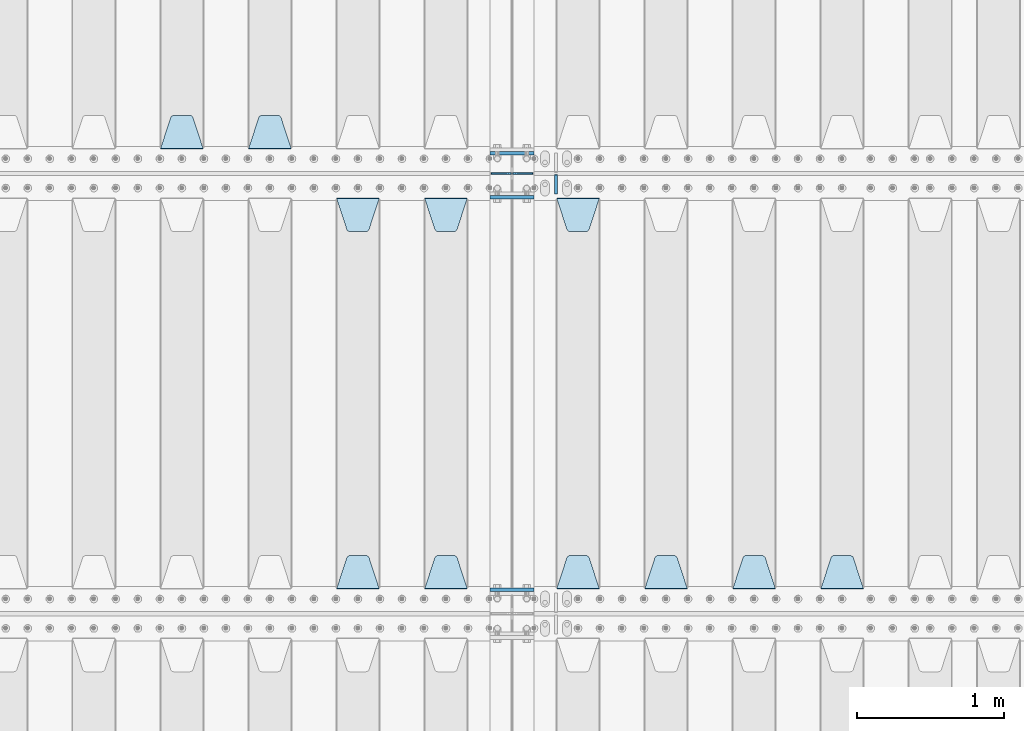
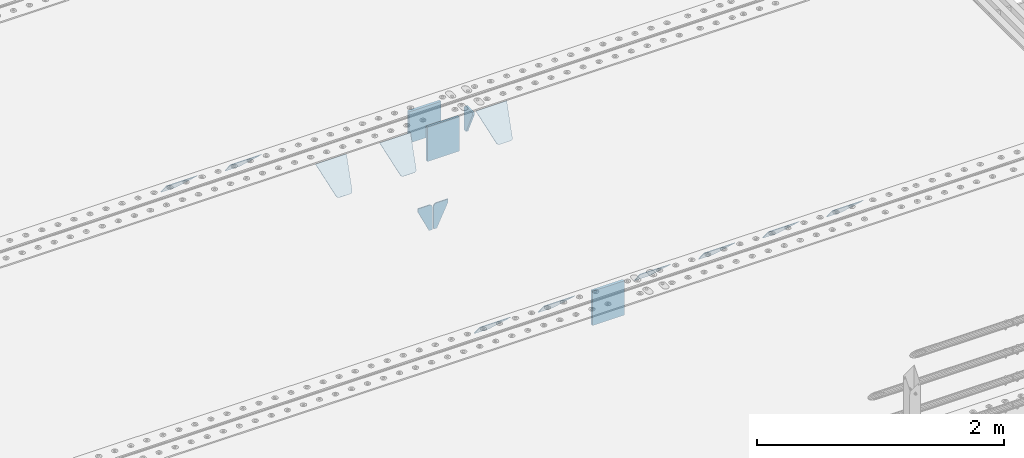
# One storey, part 215 of 257: 17 plates.
"""IFC2X3 building model written with IfcOpenShell, lengths in millimetres."""

from ifc_helpers import new_model, si_unit, frame, origin_with_axes, place, context, subcontext, project, spatial, faceted_brep, material, type_object, element, save


model = new_model("IFC2X3")

# Units and contexts
model_context = context("Model", 3, precision=1e-05, world=origin_with_axes())
body_context = subcontext(model_context, "Body", "Model", "MODEL_VIEW")
ifc_project = project(units=[si_unit("LENGTHUNIT", "METRE", prefix="MILLI"), si_unit("AREAUNIT", "SQUARE_METRE"), si_unit("VOLUMEUNIT", "CUBIC_METRE"), si_unit("MASSUNIT", "GRAM", prefix="KILO"), si_unit("TIMEUNIT", "SECOND"), si_unit("PLANEANGLEUNIT", "RADIAN"), si_unit("SOLIDANGLEUNIT", "STERADIAN"), si_unit("THERMODYNAMICTEMPERATUREUNIT", "DEGREE_CELSIUS"), si_unit("LUMINOUSINTENSITYUNIT", "LUMEN")], contexts=[model_context])

# Site, building, storey
site_placement = place(None, origin_with_axes())
site = spatial("IfcSite", under=ifc_project, at=site_placement, CompositionType="ELEMENT")
building_placement = place(site_placement, origin_with_axes())
building = spatial("IfcBuilding", under=site, at=building_placement, Name="Standard", CompositionType="ELEMENT")
storey_placement = place(building_placement, origin_with_axes())
storey = spatial("IfcBuildingStorey", under=building, at=storey_placement, Name="Undefined", CompositionType="ELEMENT", Elevation=0.0)

# Plates
ifc_material = material(Name="STEEL/S355N")
plate_type_1 = type_object("IfcPlateType", PredefinedType="NOTDEFINED")
for number, where, z_axis, x_axis in (
    (1, (54550.0, 5837.5, -340.000000000044), (0.0, 0.0, 1.0), (1.0, 0.0, 0.0)),
    (2, (54550.0, 3162.5, -340.000000000044), (0.0, 0.0, 1.0), (1.0, 0.0, 0.0)),
):
    element("IfcPlate", number, at=place(storey_placement, frame(where, z_axis=z_axis, x_axis=x_axis)), inside=storey, type_object=plate_type_1, material=ifc_material, context=body_context, shape_type="Brep", body=[
        faceted_brep([(0.0, -12.5, 0.0), (0.0, -12.5, 340.0), (0.0, 12.5, 340.0), (0.0, 12.5, 0.0), (300.0, -12.5, 340.0), (300.0, 12.5, 340.0), (300.0, -12.5, 0.0), (300.0, 12.5, 0.0)], [[[0, 1, 2, 3]], [[1, 4, 5, 2]], [[4, 6, 7, 5]], [[6, 0, 3, 7]], [[5, 7, 3, 2]], [[6, 4, 1, 0]]]),
    ])
plate_1_placement = place(storey_placement, frame((54550.0, 6137.5, -340.0), z_axis=(0.0, 0.0, 1.0), x_axis=(1.0, 0.0, 0.0)))
element("IfcPlate", 3, at=plate_1_placement, inside=storey, type_object=plate_type_1, material=ifc_material, context=body_context, shape_type="Brep", body=[
    faceted_brep([(0.0, -12.5, 0.0), (0.0, -12.5, 310.0), (0.0, 12.5, 310.0), (0.0, 12.5, 0.0), (300.0, -12.5, 310.0), (300.0, 12.5, 310.0), (300.0, -12.5, 0.0), (300.0, 12.5, 0.0)], [[[0, 1, 2, 3]], [[1, 4, 5, 2]], [[4, 6, 7, 5]], [[6, 0, 3, 7]], [[5, 7, 3, 2]], [[6, 4, 1, 0]]]),
])
plate_type_2 = type_object("IfcPlateType", PredefinedType="NOTDEFINED")
for number, where, z_axis, x_axis in (
    (4, (54693.4999999979, 6000.00000000422, -915.000019536854), (0.0, 0.0, -1.0), (-1.0, 0.0, 0.0)),
    (5, (54706.4999999981, 6000.0000000042, -915.000019536856), (0.0, 0.0, -1.0), (1.0, 0.0, 0.0)),
):
    element("IfcPlate", number, at=place(storey_placement, frame(where, z_axis=z_axis, x_axis=x_axis)), inside=storey, type_object=plate_type_2, material=ifc_material, context=body_context, shape_type="Brep", body=[
        faceted_brep([(0.0, -5.0, 27.0), (0.0, -5.0, 250.0), (0.0, 5.0, 250.0), (0.0, 5.0, 27.0), (30.0, -5.0, 250.0), (30.0, 5.0, 250.0), (135.0, -5.0, 30.0), (135.0, 5.0, 30.0), (135.0, -5.0, 0.0), (135.0, 5.0, 0.0), (27.0, -5.0, 0.0), (27.0, 5.0, 0.0), (22.311499202995, -5.0, 0.410190668670339), (22.311499202995, 5.0, 0.410190668670339), (17.7654561302043, -5.0, 1.62829923878053), (17.7654561302043, 5.0, 1.62829923878053), (13.5, -5.0, 3.6173140978201), (13.5, 5.0, 3.6173140978201), (9.64473453846585, -5.0, 6.31680003578754), (9.64473453846585, 5.0, 6.31680003578754), (6.31680003579095, -5.0, 9.64473453846347), (6.31680003579095, 5.0, 9.64473453846347), (3.61731409782078, -5.0, 13.5), (3.61731409782078, 5.0, 13.5), (1.62829923877871, -5.0, 17.765456130207), (1.62829923877871, 5.0, 17.765456130207), (0.410190668670111, -5.0, 22.3114992029929), (0.410190668670111, 5.0, 22.3114992029929)], [[[0, 1, 2, 3]], [[1, 4, 5, 2]], [[4, 6, 7, 5]], [[6, 8, 9, 7]], [[8, 10, 11, 9]], [[10, 12, 13, 11]], [[12, 14, 15, 13]], [[14, 16, 17, 15]], [[16, 18, 19, 17]], [[18, 20, 21, 19]], [[20, 22, 23, 21]], [[22, 24, 25, 23]], [[24, 26, 27, 25]], [[26, 0, 3, 27]], [[5, 7, 9, 11, 13, 15, 17, 19, 21, 23, 25, 27, 3, 2]], [[26, 24, 22, 20, 18, 16, 14, 12, 10, 8, 6, 4, 1, 0]]]),
    ])
plate_type_3 = type_object("IfcPlateType", PredefinedType="NOTDEFINED")
plate_2_placement = place(storey_placement, frame((57095.0, 3168.23223304703, -1.76776695296758), z_axis=(0.0, 0.707106781186547, -0.707106781186548), x_axis=(-1.0, 0.0, 0.0)))
element("IfcPlate", 6, at=plate_2_placement, inside=storey, type_object=plate_type_3, material=ifc_material, context=body_context, shape_type="Brep", body=[
    faceted_brep([(0.0, -2.5, 0.0), (69.345504679477, -2.50000000000091, 300.17173142483), (69.345504679477, 2.5, 300.171731424831), (0.0, 2.5, 0.0), (70.927406119954, -2.50000000000091, 304.8974424154), (70.927406119954, 2.5, 304.8974424154), (73.3818627772271, -2.50000000000091, 309.234538108527), (73.3818627772271, 2.49999999999909, 309.234538108527), (76.6187032999587, -2.5, 313.023683126103), (76.6187032999587, 2.5, 313.023683126103), (80.5190132705029, -2.5, 316.125672595372), (80.5190132705029, 2.5, 316.125672595371), (84.9395038596849, -2.5, 318.426546230476), (84.9395038596849, 2.5, 318.426546230477), (89.7177759439219, -2.5, 319.841774983275), (89.7177759439219, 2.5, 319.841774983275), (94.6782862926484, -2.5, 320.319366455079), (94.6782862926484, 2.5, 320.319366455079), (195.321713707352, -2.5, 320.319366455079), (195.321713707352, 2.5, 320.319366455079), (200.282224056078, -2.5, 319.841774983275), (200.282224056078, 2.49999999999909, 319.841774983275), (205.060496140315, -2.5, 318.426546230476), (205.060496140315, 2.49999999999909, 318.426546230475), (209.480986729497, -2.5, 316.125672595371), (209.480986729497, 2.5, 316.125672595371), (213.381296700041, -2.50000000000091, 313.023683126102), (213.381296700041, 2.5, 313.023683126103), (216.618137222766, -2.50000000000091, 309.234538108527), (216.618137222766, 2.5, 309.234538108527), (219.072593880039, -2.5, 304.897442415399), (219.072593880039, 2.5, 304.897442415399), (220.654495320523, -2.50000000000091, 300.17173142483), (220.654495320523, 2.5, 300.171731424831), (290.0, -2.50000000000091, 0.0), (290.0, 2.5, 9.09494701772928e-13)], [[[0, 1, 2, 3]], [[1, 4, 5, 2]], [[4, 6, 7, 5]], [[6, 8, 9, 7]], [[8, 10, 11, 9]], [[10, 12, 13, 11]], [[12, 14, 15, 13]], [[14, 16, 17, 15]], [[16, 18, 19, 17]], [[18, 20, 21, 19]], [[20, 22, 23, 21]], [[22, 24, 25, 23]], [[24, 26, 27, 25]], [[26, 28, 29, 27]], [[28, 30, 31, 29]], [[30, 32, 33, 31]], [[32, 34, 35, 33]], [[34, 0, 3, 35]], [[5, 7, 9, 11, 13, 15, 17, 19, 21, 23, 25, 27, 29, 31, 33, 35, 3, 2]], [[34, 32, 30, 28, 26, 24, 22, 20, 18, 16, 14, 12, 10, 8, 6, 4, 1, 0]]]),
])
plate_3_placement = place(storey_placement, frame((53195.0, 6168.23223304704, -1.76776695296758), z_axis=(0.0, 0.707106781186547, -0.707106781186548), x_axis=(-1.0, 0.0, 0.0)))
element("IfcPlate", 7, at=plate_3_placement, inside=storey, type_object=plate_type_3, material=ifc_material, context=body_context, shape_type="Brep", body=[
    faceted_brep([(0.0, -2.5, 0.0), (69.345504679477, -2.50000000000091, 300.17173142483), (69.345504679477, 2.5, 300.171731424831), (0.0, 2.5, 0.0), (70.927406119954, -2.50000000000091, 304.8974424154), (70.927406119954, 2.5, 304.8974424154), (73.3818627772271, -2.50000000000091, 309.234538108527), (73.3818627772271, 2.49999999999909, 309.234538108527), (76.6187032999587, -2.5, 313.023683126103), (76.6187032999587, 2.5, 313.023683126103), (80.5190132705029, -2.5, 316.125672595372), (80.5190132705029, 2.5, 316.125672595371), (84.9395038596849, -2.5, 318.426546230476), (84.9395038596849, 2.5, 318.426546230477), (89.7177759439219, -2.5, 319.841774983275), (89.7177759439219, 2.5, 319.841774983275), (94.6782862926484, -2.5, 320.319366455079), (94.6782862926484, 2.5, 320.319366455079), (195.321713707352, -2.5, 320.319366455079), (195.321713707352, 2.5, 320.319366455079), (200.282224056078, -2.5, 319.841774983275), (200.282224056078, 2.49999999999909, 319.841774983275), (205.060496140315, -2.5, 318.426546230476), (205.060496140315, 2.49999999999909, 318.426546230475), (209.480986729497, -2.5, 316.125672595371), (209.480986729497, 2.5, 316.125672595371), (213.381296700041, -2.50000000000091, 313.023683126102), (213.381296700041, 2.5, 313.023683126103), (216.618137222766, -2.50000000000091, 309.234538108527), (216.618137222766, 2.5, 309.234538108527), (219.072593880039, -2.5, 304.897442415399), (219.072593880039, 2.5, 304.897442415399), (220.654495320523, -2.50000000000091, 300.17173142483), (220.654495320523, 2.5, 300.171731424831), (290.0, -2.50000000000091, 0.0), (290.0, 2.5, 9.09494701772928e-13)], [[[0, 1, 2, 3]], [[1, 4, 5, 2]], [[4, 6, 7, 5]], [[6, 8, 9, 7]], [[8, 10, 11, 9]], [[10, 12, 13, 11]], [[12, 14, 15, 13]], [[14, 16, 17, 15]], [[16, 18, 19, 17]], [[18, 20, 21, 19]], [[20, 22, 23, 21]], [[22, 24, 25, 23]], [[24, 26, 27, 25]], [[26, 28, 29, 27]], [[28, 30, 31, 29]], [[30, 32, 33, 31]], [[32, 34, 35, 33]], [[34, 0, 3, 35]], [[5, 7, 9, 11, 13, 15, 17, 19, 21, 23, 25, 27, 29, 31, 33, 35, 3, 2]], [[34, 32, 30, 28, 26, 24, 22, 20, 18, 16, 14, 12, 10, 8, 6, 4, 1, 0]]]),
])
plate_4_placement = place(storey_placement, frame((52595.0, 6168.23223304703, -1.76776695296758), z_axis=(0.0, 0.707106781186547, -0.707106781186548), x_axis=(-1.0, 0.0, 0.0)))
element("IfcPlate", 8, at=plate_4_placement, inside=storey, type_object=plate_type_3, material=ifc_material, context=body_context, shape_type="Brep", body=[
    faceted_brep([(0.0, -2.5, 0.0), (69.345504679477, -2.50000000000091, 300.17173142483), (69.345504679477, 2.5, 300.171731424831), (0.0, 2.5, 0.0), (70.927406119954, -2.50000000000091, 304.8974424154), (70.927406119954, 2.5, 304.8974424154), (73.3818627772271, -2.50000000000091, 309.234538108527), (73.3818627772271, 2.49999999999909, 309.234538108527), (76.6187032999587, -2.5, 313.023683126103), (76.6187032999587, 2.5, 313.023683126103), (80.5190132705029, -2.5, 316.125672595372), (80.5190132705029, 2.5, 316.125672595371), (84.9395038596849, -2.5, 318.426546230476), (84.9395038596849, 2.5, 318.426546230477), (89.7177759439219, -2.5, 319.841774983275), (89.7177759439219, 2.5, 319.841774983275), (94.6782862926484, -2.5, 320.319366455079), (94.6782862926484, 2.5, 320.319366455079), (195.321713707352, -2.5, 320.319366455079), (195.321713707352, 2.5, 320.319366455079), (200.282224056078, -2.5, 319.841774983275), (200.282224056078, 2.49999999999909, 319.841774983275), (205.060496140315, -2.5, 318.426546230476), (205.060496140315, 2.49999999999909, 318.426546230475), (209.480986729497, -2.5, 316.125672595371), (209.480986729497, 2.5, 316.125672595371), (213.381296700041, -2.50000000000091, 313.023683126102), (213.381296700041, 2.5, 313.023683126103), (216.618137222766, -2.50000000000091, 309.234538108527), (216.618137222766, 2.5, 309.234538108527), (219.072593880039, -2.5, 304.897442415399), (219.072593880039, 2.5, 304.897442415399), (220.654495320523, -2.50000000000091, 300.17173142483), (220.654495320523, 2.5, 300.171731424831), (290.0, -2.50000000000091, 0.0), (290.0, 2.5, 9.09494701772928e-13)], [[[0, 1, 2, 3]], [[1, 4, 5, 2]], [[4, 6, 7, 5]], [[6, 8, 9, 7]], [[8, 10, 11, 9]], [[10, 12, 13, 11]], [[12, 14, 15, 13]], [[14, 16, 17, 15]], [[16, 18, 19, 17]], [[18, 20, 21, 19]], [[20, 22, 23, 21]], [[22, 24, 25, 23]], [[24, 26, 27, 25]], [[26, 28, 29, 27]], [[28, 30, 31, 29]], [[30, 32, 33, 31]], [[32, 34, 35, 33]], [[34, 0, 3, 35]], [[5, 7, 9, 11, 13, 15, 17, 19, 21, 23, 25, 27, 29, 31, 33, 35, 3, 2]], [[34, 32, 30, 28, 26, 24, 22, 20, 18, 16, 14, 12, 10, 8, 6, 4, 1, 0]]]),
])
plate_5_placement = place(storey_placement, frame((56495.0, 3168.23223304703, -1.76776695296758), z_axis=(0.0, 0.707106781186547, -0.707106781186548), x_axis=(-1.0, 0.0, 0.0)))
element("IfcPlate", 9, at=plate_5_placement, inside=storey, type_object=plate_type_3, material=ifc_material, context=body_context, shape_type="Brep", body=[
    faceted_brep([(0.0, -2.5, 0.0), (69.345504679477, -2.50000000000091, 300.17173142483), (69.345504679477, 2.5, 300.171731424831), (0.0, 2.5, 0.0), (70.927406119954, -2.50000000000091, 304.8974424154), (70.927406119954, 2.5, 304.8974424154), (73.3818627772271, -2.50000000000091, 309.234538108527), (73.3818627772271, 2.49999999999909, 309.234538108527), (76.6187032999587, -2.5, 313.023683126103), (76.6187032999587, 2.5, 313.023683126103), (80.5190132705029, -2.5, 316.125672595372), (80.5190132705029, 2.5, 316.125672595371), (84.9395038596849, -2.5, 318.426546230476), (84.9395038596849, 2.5, 318.426546230477), (89.7177759439219, -2.5, 319.841774983275), (89.7177759439219, 2.5, 319.841774983275), (94.6782862926484, -2.5, 320.319366455079), (94.6782862926484, 2.5, 320.319366455079), (195.321713707352, -2.5, 320.319366455079), (195.321713707352, 2.5, 320.319366455079), (200.282224056078, -2.5, 319.841774983275), (200.282224056078, 2.49999999999909, 319.841774983275), (205.060496140315, -2.5, 318.426546230476), (205.060496140315, 2.49999999999909, 318.426546230475), (209.480986729497, -2.5, 316.125672595371), (209.480986729497, 2.5, 316.125672595371), (213.381296700041, -2.50000000000091, 313.023683126102), (213.381296700041, 2.5, 313.023683126103), (216.618137222766, -2.50000000000091, 309.234538108527), (216.618137222766, 2.5, 309.234538108527), (219.072593880039, -2.5, 304.897442415399), (219.072593880039, 2.5, 304.897442415399), (220.654495320523, -2.50000000000091, 300.17173142483), (220.654495320523, 2.5, 300.171731424831), (290.0, -2.50000000000091, 0.0), (290.0, 2.5, 9.09494701772928e-13)], [[[0, 1, 2, 3]], [[1, 4, 5, 2]], [[4, 6, 7, 5]], [[6, 8, 9, 7]], [[8, 10, 11, 9]], [[10, 12, 13, 11]], [[12, 14, 15, 13]], [[14, 16, 17, 15]], [[16, 18, 19, 17]], [[18, 20, 21, 19]], [[20, 22, 23, 21]], [[22, 24, 25, 23]], [[24, 26, 27, 25]], [[26, 28, 29, 27]], [[28, 30, 31, 29]], [[30, 32, 33, 31]], [[32, 34, 35, 33]], [[34, 0, 3, 35]], [[5, 7, 9, 11, 13, 15, 17, 19, 21, 23, 25, 27, 29, 31, 33, 35, 3, 2]], [[34, 32, 30, 28, 26, 24, 22, 20, 18, 16, 14, 12, 10, 8, 6, 4, 1, 0]]]),
])
plate_6_placement = place(storey_placement, frame((55895.0, 3168.23223304703, -1.76776695296758), z_axis=(0.0, 0.707106781186547, -0.707106781186548), x_axis=(-1.0, 0.0, 0.0)))
element("IfcPlate", 10, at=plate_6_placement, inside=storey, type_object=plate_type_3, material=ifc_material, context=body_context, shape_type="Brep", body=[
    faceted_brep([(0.0, -2.5, 0.0), (69.345504679477, -2.50000000000091, 300.17173142483), (69.345504679477, 2.5, 300.171731424831), (0.0, 2.5, 0.0), (70.927406119954, -2.50000000000091, 304.8974424154), (70.927406119954, 2.5, 304.8974424154), (73.3818627772271, -2.50000000000091, 309.234538108527), (73.3818627772271, 2.49999999999909, 309.234538108527), (76.6187032999587, -2.5, 313.023683126103), (76.6187032999587, 2.5, 313.023683126103), (80.5190132705029, -2.5, 316.125672595372), (80.5190132705029, 2.5, 316.125672595371), (84.9395038596849, -2.5, 318.426546230476), (84.9395038596849, 2.5, 318.426546230477), (89.7177759439219, -2.5, 319.841774983275), (89.7177759439219, 2.5, 319.841774983275), (94.6782862926484, -2.5, 320.319366455079), (94.6782862926484, 2.5, 320.319366455079), (195.321713707352, -2.5, 320.319366455079), (195.321713707352, 2.5, 320.319366455079), (200.282224056078, -2.5, 319.841774983275), (200.282224056078, 2.49999999999909, 319.841774983275), (205.060496140315, -2.5, 318.426546230476), (205.060496140315, 2.49999999999909, 318.426546230475), (209.480986729497, -2.5, 316.125672595371), (209.480986729497, 2.5, 316.125672595371), (213.381296700041, -2.50000000000091, 313.023683126102), (213.381296700041, 2.5, 313.023683126103), (216.618137222766, -2.50000000000091, 309.234538108527), (216.618137222766, 2.5, 309.234538108527), (219.072593880039, -2.5, 304.897442415399), (219.072593880039, 2.5, 304.897442415399), (220.654495320523, -2.50000000000091, 300.17173142483), (220.654495320523, 2.5, 300.171731424831), (290.0, -2.50000000000091, 0.0), (290.0, 2.5, 9.09494701772928e-13)], [[[0, 1, 2, 3]], [[1, 4, 5, 2]], [[4, 6, 7, 5]], [[6, 8, 9, 7]], [[8, 10, 11, 9]], [[10, 12, 13, 11]], [[12, 14, 15, 13]], [[14, 16, 17, 15]], [[16, 18, 19, 17]], [[18, 20, 21, 19]], [[20, 22, 23, 21]], [[22, 24, 25, 23]], [[24, 26, 27, 25]], [[26, 28, 29, 27]], [[28, 30, 31, 29]], [[30, 32, 33, 31]], [[32, 34, 35, 33]], [[34, 0, 3, 35]], [[5, 7, 9, 11, 13, 15, 17, 19, 21, 23, 25, 27, 29, 31, 33, 35, 3, 2]], [[34, 32, 30, 28, 26, 24, 22, 20, 18, 16, 14, 12, 10, 8, 6, 4, 1, 0]]]),
])
plate_7_placement = place(storey_placement, frame((55005.0, 5831.76776695594, -1.767766952965), z_axis=(0.0, -0.707106781186548, -0.707106781186547), x_axis=(1.0, 0.0, 0.0)))
element("IfcPlate", 11, at=plate_7_placement, inside=storey, type_object=plate_type_3, material=ifc_material, context=body_context, shape_type="Brep", body=[
    faceted_brep([(0.0, -2.5, 0.0), (69.345504679477, -2.50000000000091, 300.17173142483), (69.345504679477, 2.5, 300.171731424831), (0.0, 2.5, 0.0), (70.927406119954, -2.50000000000091, 304.8974424154), (70.927406119954, 2.5, 304.8974424154), (73.3818627772271, -2.50000000000091, 309.234538108527), (73.3818627772271, 2.49999999999909, 309.234538108527), (76.6187032999587, -2.5, 313.023683126103), (76.6187032999587, 2.5, 313.023683126103), (80.5190132705029, -2.5, 316.125672595372), (80.5190132705029, 2.5, 316.125672595371), (84.9395038596849, -2.5, 318.426546230476), (84.9395038596849, 2.5, 318.426546230477), (89.7177759439219, -2.5, 319.841774983275), (89.7177759439219, 2.5, 319.841774983275), (94.6782862926484, -2.5, 320.319366455079), (94.6782862926484, 2.5, 320.319366455079), (195.321713707352, -2.5, 320.319366455079), (195.321713707352, 2.5, 320.319366455079), (200.282224056078, -2.5, 319.841774983275), (200.282224056078, 2.49999999999909, 319.841774983275), (205.060496140315, -2.5, 318.426546230476), (205.060496140315, 2.49999999999909, 318.426546230475), (209.480986729497, -2.5, 316.125672595371), (209.480986729497, 2.5, 316.125672595371), (213.381296700041, -2.50000000000091, 313.023683126102), (213.381296700041, 2.5, 313.023683126103), (216.618137222766, -2.50000000000091, 309.234538108527), (216.618137222766, 2.5, 309.234538108527), (219.072593880039, -2.5, 304.897442415399), (219.072593880039, 2.5, 304.897442415399), (220.654495320523, -2.50000000000091, 300.17173142483), (220.654495320523, 2.5, 300.171731424831), (290.0, -2.50000000000091, 0.0), (290.0, 2.5, 9.09494701772928e-13)], [[[0, 1, 2, 3]], [[1, 4, 5, 2]], [[4, 6, 7, 5]], [[6, 8, 9, 7]], [[8, 10, 11, 9]], [[10, 12, 13, 11]], [[12, 14, 15, 13]], [[14, 16, 17, 15]], [[16, 18, 19, 17]], [[18, 20, 21, 19]], [[20, 22, 23, 21]], [[22, 24, 25, 23]], [[24, 26, 27, 25]], [[26, 28, 29, 27]], [[28, 30, 31, 29]], [[30, 32, 33, 31]], [[32, 34, 35, 33]], [[34, 0, 3, 35]], [[5, 7, 9, 11, 13, 15, 17, 19, 21, 23, 25, 27, 29, 31, 33, 35, 3, 2]], [[34, 32, 30, 28, 26, 24, 22, 20, 18, 16, 14, 12, 10, 8, 6, 4, 1, 0]]]),
])
plate_8_placement = place(storey_placement, frame((55295.0, 3168.23223304703, -1.76776695296758), z_axis=(0.0, 0.707106781186547, -0.707106781186548), x_axis=(-1.0, 0.0, 0.0)))
element("IfcPlate", 12, at=plate_8_placement, inside=storey, type_object=plate_type_3, material=ifc_material, context=body_context, shape_type="Brep", body=[
    faceted_brep([(0.0, -2.5, 0.0), (69.345504679477, -2.50000000000091, 300.17173142483), (69.345504679477, 2.5, 300.171731424831), (0.0, 2.5, 0.0), (70.927406119954, -2.50000000000091, 304.8974424154), (70.927406119954, 2.5, 304.8974424154), (73.3818627772271, -2.50000000000091, 309.234538108527), (73.3818627772271, 2.49999999999909, 309.234538108527), (76.6187032999587, -2.5, 313.023683126103), (76.6187032999587, 2.5, 313.023683126103), (80.5190132705029, -2.5, 316.125672595372), (80.5190132705029, 2.5, 316.125672595371), (84.9395038596849, -2.5, 318.426546230476), (84.9395038596849, 2.5, 318.426546230477), (89.7177759439219, -2.5, 319.841774983275), (89.7177759439219, 2.5, 319.841774983275), (94.6782862926484, -2.5, 320.319366455079), (94.6782862926484, 2.5, 320.319366455079), (195.321713707352, -2.5, 320.319366455079), (195.321713707352, 2.5, 320.319366455079), (200.282224056078, -2.5, 319.841774983275), (200.282224056078, 2.49999999999909, 319.841774983275), (205.060496140315, -2.5, 318.426546230476), (205.060496140315, 2.49999999999909, 318.426546230475), (209.480986729497, -2.5, 316.125672595371), (209.480986729497, 2.5, 316.125672595371), (213.381296700041, -2.50000000000091, 313.023683126102), (213.381296700041, 2.5, 313.023683126103), (216.618137222766, -2.50000000000091, 309.234538108527), (216.618137222766, 2.5, 309.234538108527), (219.072593880039, -2.5, 304.897442415399), (219.072593880039, 2.5, 304.897442415399), (220.654495320523, -2.50000000000091, 300.17173142483), (220.654495320523, 2.5, 300.171731424831), (290.0, -2.50000000000091, 0.0), (290.0, 2.5, 9.09494701772928e-13)], [[[0, 1, 2, 3]], [[1, 4, 5, 2]], [[4, 6, 7, 5]], [[6, 8, 9, 7]], [[8, 10, 11, 9]], [[10, 12, 13, 11]], [[12, 14, 15, 13]], [[14, 16, 17, 15]], [[16, 18, 19, 17]], [[18, 20, 21, 19]], [[20, 22, 23, 21]], [[22, 24, 25, 23]], [[24, 26, 27, 25]], [[26, 28, 29, 27]], [[28, 30, 31, 29]], [[30, 32, 33, 31]], [[32, 34, 35, 33]], [[34, 0, 3, 35]], [[5, 7, 9, 11, 13, 15, 17, 19, 21, 23, 25, 27, 29, 31, 33, 35, 3, 2]], [[34, 32, 30, 28, 26, 24, 22, 20, 18, 16, 14, 12, 10, 8, 6, 4, 1, 0]]]),
])
plate_9_placement = place(storey_placement, frame((54105.0, 5831.76776695594, -1.767766952965), z_axis=(0.0, -0.707106781186548, -0.707106781186547), x_axis=(1.0, 0.0, 0.0)))
element("IfcPlate", 13, at=plate_9_placement, inside=storey, type_object=plate_type_3, material=ifc_material, context=body_context, shape_type="Brep", body=[
    faceted_brep([(0.0, -2.5, 0.0), (69.345504679477, -2.50000000000091, 300.17173142483), (69.345504679477, 2.5, 300.171731424831), (0.0, 2.5, 0.0), (70.927406119954, -2.50000000000091, 304.8974424154), (70.927406119954, 2.5, 304.8974424154), (73.3818627772271, -2.50000000000091, 309.234538108527), (73.3818627772271, 2.49999999999909, 309.234538108527), (76.6187032999587, -2.5, 313.023683126103), (76.6187032999587, 2.5, 313.023683126103), (80.5190132705029, -2.5, 316.125672595372), (80.5190132705029, 2.5, 316.125672595371), (84.9395038596849, -2.5, 318.426546230476), (84.9395038596849, 2.5, 318.426546230477), (89.7177759439219, -2.5, 319.841774983275), (89.7177759439219, 2.5, 319.841774983275), (94.6782862926484, -2.5, 320.319366455079), (94.6782862926484, 2.5, 320.319366455079), (195.321713707352, -2.5, 320.319366455079), (195.321713707352, 2.5, 320.319366455079), (200.282224056078, -2.5, 319.841774983275), (200.282224056078, 2.49999999999909, 319.841774983275), (205.060496140315, -2.5, 318.426546230476), (205.060496140315, 2.49999999999909, 318.426546230475), (209.480986729497, -2.5, 316.125672595371), (209.480986729497, 2.5, 316.125672595371), (213.381296700041, -2.50000000000091, 313.023683126102), (213.381296700041, 2.5, 313.023683126103), (216.618137222766, -2.50000000000091, 309.234538108527), (216.618137222766, 2.5, 309.234538108527), (219.072593880039, -2.5, 304.897442415399), (219.072593880039, 2.5, 304.897442415399), (220.654495320523, -2.50000000000091, 300.17173142483), (220.654495320523, 2.5, 300.171731424831), (290.0, -2.50000000000091, 0.0), (290.0, 2.5, 9.09494701772928e-13)], [[[0, 1, 2, 3]], [[1, 4, 5, 2]], [[4, 6, 7, 5]], [[6, 8, 9, 7]], [[8, 10, 11, 9]], [[10, 12, 13, 11]], [[12, 14, 15, 13]], [[14, 16, 17, 15]], [[16, 18, 19, 17]], [[18, 20, 21, 19]], [[20, 22, 23, 21]], [[22, 24, 25, 23]], [[24, 26, 27, 25]], [[26, 28, 29, 27]], [[28, 30, 31, 29]], [[30, 32, 33, 31]], [[32, 34, 35, 33]], [[34, 0, 3, 35]], [[5, 7, 9, 11, 13, 15, 17, 19, 21, 23, 25, 27, 29, 31, 33, 35, 3, 2]], [[34, 32, 30, 28, 26, 24, 22, 20, 18, 16, 14, 12, 10, 8, 6, 4, 1, 0]]]),
])
plate_10_placement = place(storey_placement, frame((54395.0, 3168.23223304703, -1.76776695296758), z_axis=(0.0, 0.707106781186547, -0.707106781186548), x_axis=(-1.0, 0.0, 0.0)))
element("IfcPlate", 14, at=plate_10_placement, inside=storey, type_object=plate_type_3, material=ifc_material, context=body_context, shape_type="Brep", body=[
    faceted_brep([(0.0, -2.5, 0.0), (69.345504679477, -2.50000000000091, 300.17173142483), (69.345504679477, 2.5, 300.171731424831), (0.0, 2.5, 0.0), (70.927406119954, -2.50000000000091, 304.8974424154), (70.927406119954, 2.5, 304.8974424154), (73.3818627772271, -2.50000000000091, 309.234538108527), (73.3818627772271, 2.49999999999909, 309.234538108527), (76.6187032999587, -2.5, 313.023683126103), (76.6187032999587, 2.5, 313.023683126103), (80.5190132705029, -2.5, 316.125672595372), (80.5190132705029, 2.5, 316.125672595371), (84.9395038596849, -2.5, 318.426546230476), (84.9395038596849, 2.5, 318.426546230477), (89.7177759439219, -2.5, 319.841774983275), (89.7177759439219, 2.5, 319.841774983275), (94.6782862926484, -2.5, 320.319366455079), (94.6782862926484, 2.5, 320.319366455079), (195.321713707352, -2.5, 320.319366455079), (195.321713707352, 2.5, 320.319366455079), (200.282224056078, -2.5, 319.841774983275), (200.282224056078, 2.49999999999909, 319.841774983275), (205.060496140315, -2.5, 318.426546230476), (205.060496140315, 2.49999999999909, 318.426546230475), (209.480986729497, -2.5, 316.125672595371), (209.480986729497, 2.5, 316.125672595371), (213.381296700041, -2.50000000000091, 313.023683126102), (213.381296700041, 2.5, 313.023683126103), (216.618137222766, -2.50000000000091, 309.234538108527), (216.618137222766, 2.5, 309.234538108527), (219.072593880039, -2.5, 304.897442415399), (219.072593880039, 2.5, 304.897442415399), (220.654495320523, -2.50000000000091, 300.17173142483), (220.654495320523, 2.5, 300.171731424831), (290.0, -2.50000000000091, 0.0), (290.0, 2.5, 9.09494701772928e-13)], [[[0, 1, 2, 3]], [[1, 4, 5, 2]], [[4, 6, 7, 5]], [[6, 8, 9, 7]], [[8, 10, 11, 9]], [[10, 12, 13, 11]], [[12, 14, 15, 13]], [[14, 16, 17, 15]], [[16, 18, 19, 17]], [[18, 20, 21, 19]], [[20, 22, 23, 21]], [[22, 24, 25, 23]], [[24, 26, 27, 25]], [[26, 28, 29, 27]], [[28, 30, 31, 29]], [[30, 32, 33, 31]], [[32, 34, 35, 33]], [[34, 0, 3, 35]], [[5, 7, 9, 11, 13, 15, 17, 19, 21, 23, 25, 27, 29, 31, 33, 35, 3, 2]], [[34, 32, 30, 28, 26, 24, 22, 20, 18, 16, 14, 12, 10, 8, 6, 4, 1, 0]]]),
])
plate_11_placement = place(storey_placement, frame((53505.0, 5831.76776695594, -1.767766952965), z_axis=(0.0, -0.707106781186548, -0.707106781186547), x_axis=(1.0, 0.0, 0.0)))
element("IfcPlate", 15, at=plate_11_placement, inside=storey, type_object=plate_type_3, material=ifc_material, context=body_context, shape_type="Brep", body=[
    faceted_brep([(0.0, -2.5, 0.0), (69.345504679477, -2.50000000000091, 300.17173142483), (69.345504679477, 2.5, 300.171731424831), (0.0, 2.5, 0.0), (70.927406119954, -2.50000000000091, 304.8974424154), (70.927406119954, 2.5, 304.8974424154), (73.3818627772271, -2.50000000000091, 309.234538108527), (73.3818627772271, 2.49999999999909, 309.234538108527), (76.6187032999587, -2.5, 313.023683126103), (76.6187032999587, 2.5, 313.023683126103), (80.5190132705029, -2.5, 316.125672595372), (80.5190132705029, 2.5, 316.125672595371), (84.9395038596849, -2.5, 318.426546230476), (84.9395038596849, 2.5, 318.426546230477), (89.7177759439219, -2.5, 319.841774983275), (89.7177759439219, 2.5, 319.841774983275), (94.6782862926484, -2.5, 320.319366455079), (94.6782862926484, 2.5, 320.319366455079), (195.321713707352, -2.5, 320.319366455079), (195.321713707352, 2.5, 320.319366455079), (200.282224056078, -2.5, 319.841774983275), (200.282224056078, 2.49999999999909, 319.841774983275), (205.060496140315, -2.5, 318.426546230476), (205.060496140315, 2.49999999999909, 318.426546230475), (209.480986729497, -2.5, 316.125672595371), (209.480986729497, 2.5, 316.125672595371), (213.381296700041, -2.50000000000091, 313.023683126102), (213.381296700041, 2.5, 313.023683126103), (216.618137222766, -2.50000000000091, 309.234538108527), (216.618137222766, 2.5, 309.234538108527), (219.072593880039, -2.5, 304.897442415399), (219.072593880039, 2.5, 304.897442415399), (220.654495320523, -2.50000000000091, 300.17173142483), (220.654495320523, 2.5, 300.171731424831), (290.0, -2.50000000000091, 0.0), (290.0, 2.5, 9.09494701772928e-13)], [[[0, 1, 2, 3]], [[1, 4, 5, 2]], [[4, 6, 7, 5]], [[6, 8, 9, 7]], [[8, 10, 11, 9]], [[10, 12, 13, 11]], [[12, 14, 15, 13]], [[14, 16, 17, 15]], [[16, 18, 19, 17]], [[18, 20, 21, 19]], [[20, 22, 23, 21]], [[22, 24, 25, 23]], [[24, 26, 27, 25]], [[26, 28, 29, 27]], [[28, 30, 31, 29]], [[30, 32, 33, 31]], [[32, 34, 35, 33]], [[34, 0, 3, 35]], [[5, 7, 9, 11, 13, 15, 17, 19, 21, 23, 25, 27, 29, 31, 33, 35, 3, 2]], [[34, 32, 30, 28, 26, 24, 22, 20, 18, 16, 14, 12, 10, 8, 6, 4, 1, 0]]]),
])
plate_12_placement = place(storey_placement, frame((53795.0, 3168.23223304703, -1.76776695296758), z_axis=(0.0, 0.707106781186547, -0.707106781186548), x_axis=(-1.0, 0.0, 0.0)))
element("IfcPlate", 16, at=plate_12_placement, inside=storey, type_object=plate_type_3, material=ifc_material, context=body_context, shape_type="Brep", body=[
    faceted_brep([(0.0, -2.5, 0.0), (69.345504679477, -2.50000000000091, 300.17173142483), (69.345504679477, 2.5, 300.171731424831), (0.0, 2.5, 0.0), (70.927406119954, -2.50000000000091, 304.8974424154), (70.927406119954, 2.5, 304.8974424154), (73.3818627772271, -2.50000000000091, 309.234538108527), (73.3818627772271, 2.49999999999909, 309.234538108527), (76.6187032999587, -2.5, 313.023683126103), (76.6187032999587, 2.5, 313.023683126103), (80.5190132705029, -2.5, 316.125672595372), (80.5190132705029, 2.5, 316.125672595371), (84.9395038596849, -2.5, 318.426546230476), (84.9395038596849, 2.5, 318.426546230477), (89.7177759439219, -2.5, 319.841774983275), (89.7177759439219, 2.5, 319.841774983275), (94.6782862926484, -2.5, 320.319366455079), (94.6782862926484, 2.5, 320.319366455079), (195.321713707352, -2.5, 320.319366455079), (195.321713707352, 2.5, 320.319366455079), (200.282224056078, -2.5, 319.841774983275), (200.282224056078, 2.49999999999909, 319.841774983275), (205.060496140315, -2.5, 318.426546230476), (205.060496140315, 2.49999999999909, 318.426546230475), (209.480986729497, -2.5, 316.125672595371), (209.480986729497, 2.5, 316.125672595371), (213.381296700041, -2.50000000000091, 313.023683126102), (213.381296700041, 2.5, 313.023683126103), (216.618137222766, -2.50000000000091, 309.234538108527), (216.618137222766, 2.5, 309.234538108527), (219.072593880039, -2.5, 304.897442415399), (219.072593880039, 2.5, 304.897442415399), (220.654495320523, -2.50000000000091, 300.17173142483), (220.654495320523, 2.5, 300.171731424831), (290.0, -2.50000000000091, 0.0), (290.0, 2.5, 9.09494701772928e-13)], [[[0, 1, 2, 3]], [[1, 4, 5, 2]], [[4, 6, 7, 5]], [[6, 8, 9, 7]], [[8, 10, 11, 9]], [[10, 12, 13, 11]], [[12, 14, 15, 13]], [[14, 16, 17, 15]], [[16, 18, 19, 17]], [[18, 20, 21, 19]], [[20, 22, 23, 21]], [[22, 24, 25, 23]], [[24, 26, 27, 25]], [[26, 28, 29, 27]], [[28, 30, 31, 29]], [[30, 32, 33, 31]], [[32, 34, 35, 33]], [[34, 0, 3, 35]], [[5, 7, 9, 11, 13, 15, 17, 19, 21, 23, 25, 27, 29, 31, 33, 35, 3, 2]], [[34, 32, 30, 28, 26, 24, 22, 20, 18, 16, 14, 12, 10, 8, 6, 4, 1, 0]]]),
])
plate_type_4 = type_object("IfcPlateType", PredefinedType="NOTDEFINED")
plate_13_placement = place(storey_placement, frame((55000.0, 5860.0, -30.0), z_axis=(0.0, 0.0, -1.0), x_axis=(0.0, 1.0, 0.0)))
element("IfcPlate", 17, at=plate_13_placement, inside=storey, type_object=plate_type_4, material=ifc_material, context=body_context, shape_type="Brep", body=[
    faceted_brep([(0.0, -10.0, 0.0), (0.0, -10.0, 30.0), (0.0, 10.0, 30.0), (0.0, 10.0, 0.0), (102.0, -10.0, 250.0), (102.0, 10.0, 250.0), (132.0, -10.0, 250.0), (132.0, 10.0, 250.0), (132.0, -10.0, 30.0), (132.0, 10.0, 30.0), (131.544232590366, -10.0, 24.790554669992), (131.544232590366, 10.0, 24.790554669992), (130.190778623577, -10.0, 19.7393957002299), (130.190778623577, 10.0, 19.7393957002299), (127.980762113533, -10.0, 15.0), (127.980762113533, 10.0, 15.0), (124.981333293569, -10.0, 10.7163717094038), (124.981333293569, 10.0, 10.7163717094038), (121.283628290596, -10.0, 7.01866670643062), (121.283628290596, 10.0, 7.01866670643062), (117.0, -10.0, 4.01923788646684), (117.0, 10.0, 4.01923788646684), (112.26060429977, -10.0, 1.80922137642278), (112.26060429977, 10.0, 1.80922137642278), (107.209445330008, -10.0, 0.455767409633722), (107.209445330008, 10.0, 0.455767409633722), (102.0, -10.0, 0.0), (102.0, 10.0, 0.0)], [[[0, 1, 2, 3]], [[1, 4, 5, 2]], [[4, 6, 7, 5]], [[6, 8, 9, 7]], [[8, 10, 11, 9]], [[10, 12, 13, 11]], [[12, 14, 15, 13]], [[14, 16, 17, 15]], [[16, 18, 19, 17]], [[18, 20, 21, 19]], [[20, 22, 23, 21]], [[22, 24, 25, 23]], [[24, 26, 27, 25]], [[26, 0, 3, 27]], [[5, 7, 9, 11, 13, 15, 17, 19, 21, 23, 25, 27, 3, 2]], [[26, 24, 22, 20, 18, 16, 14, 12, 10, 8, 6, 4, 1, 0]]]),
])

save(model, "model.ifc")
